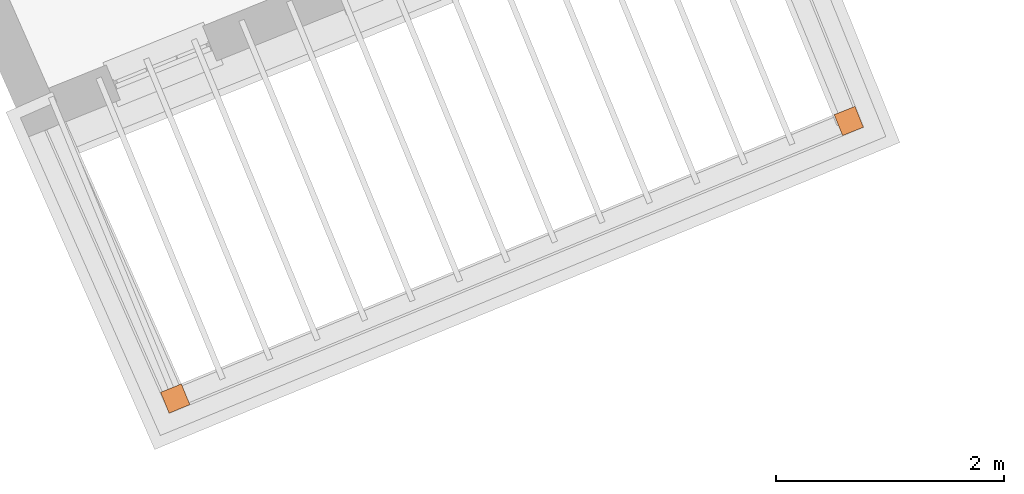
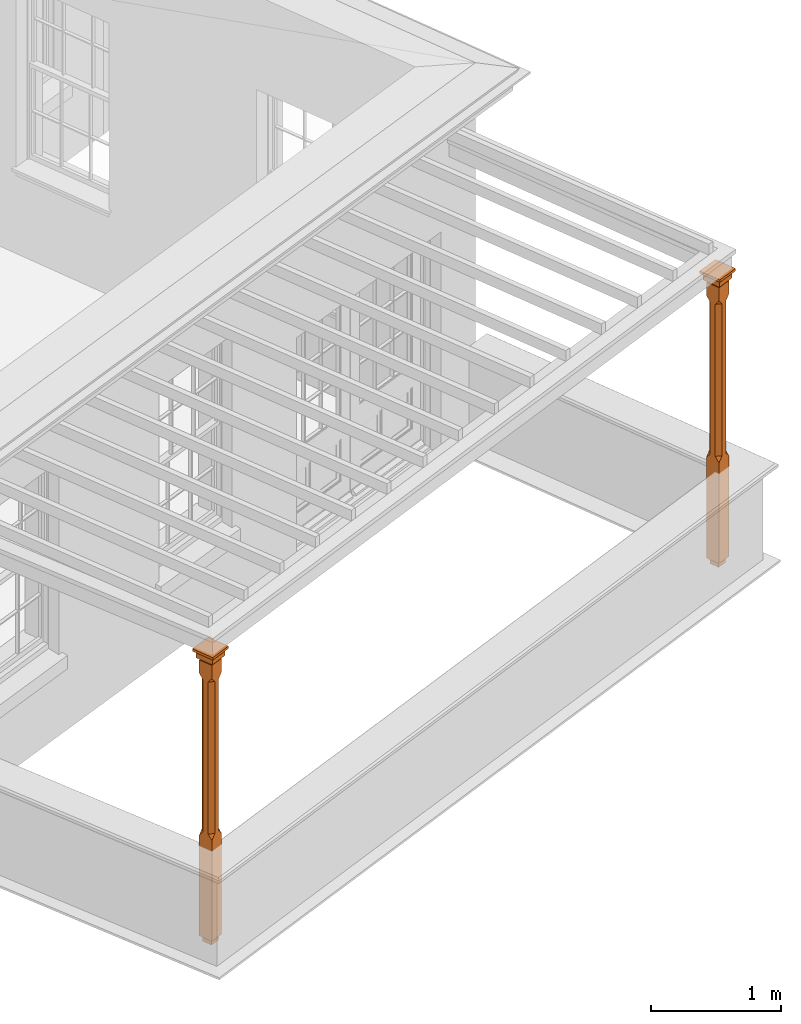
# One storey, part 11 of 11: 2 proxies.
"""IFC2X3 building model written with IfcOpenShell, lengths in metres."""

from ifc_helpers import new_model, si_unit, frame, origin, place, context, subcontext, project, spatial, faceted_brep, element, save


model = new_model("IFC2X3")

# Units and contexts
model_context = context("Model", 3, world=origin())
body_context = subcontext(model_context, "Body", "Model", "MODEL_VIEW")
ifc_project = project(units=[si_unit("PLANEANGLEUNIT", "RADIAN"), si_unit("MASSUNIT", "GRAM", prefix="KILO"), si_unit("FORCEUNIT", "NEWTON", prefix="KILO"), si_unit("LENGTHUNIT", "METRE")], contexts=[model_context])

# Site, building, storey
site_placement = place(None, origin())
site = spatial("IfcSite", under=ifc_project, at=site_placement, CompositionType="ELEMENT")
building_placement = place(None, origin())
building = spatial("IfcBuilding", under=site, at=building_placement, Name="Building plot-6", CompositionType="ELEMENT")
storey_placement = place(None, frame((0.0, 0.0, 7.6)))
storey = spatial("IfcBuildingStorey", under=building, at=storey_placement, Name="Floor 1", CompositionType="ELEMENT", Elevation=7.6)

# Proxies
proxy_1_placement = place(storey_placement, frame((68.3815028895231, 53.2647282573946, 0.0), z_axis=(0.0, 0.0, 1.0), x_axis=(0.9245784791748, 0.380991648001388, 0.0)))
element("IfcBuildingElementProxy", 1, at=proxy_1_placement, inside=storey, Name="pergola post", CompositionType="ELEMENT", context=body_context, shape_type="Brep", held_by="IfcProductRepresentation", body=[
    faceted_brep([(0.0246, -0.0615, 2.47), (0.0615, -0.0246, 2.47), (0.0615, -0.0615, 2.516667), (0.0615, -0.0246, 1.044444), (0.0246, -0.0615, 1.044444), (0.0615, 0.0246, 2.47), (0.0615, 0.0615, 2.516667), (-0.0246, -0.0615, 2.47), (-0.0615, -0.0615, 2.516667), (-0.0246, -0.0615, 1.044444), (0.0615, -0.0615, 0.997778), (0.0615, 0.0246, 1.044444), (0.0246, 0.0615, 2.47), (0.0615, 0.0615, 2.641111), (0.0615, -0.0615, 2.641111), (-0.0615, -0.0615, 2.641111), (-0.0615, -0.0246, 2.47), (-0.0615, -0.0246, 1.044444), (-0.0615, -0.0615, 0.997778), (0.0615, 0.0615, 0.997778), (0.0246, 0.0615, 1.044444), (-0.0246, 0.0615, 2.47), (-0.0615, 0.0615, 2.516667), (0.04305, 0.04305, 2.641111), (0.04305, -0.04305, 2.641111), (-0.0615, 0.0615, 2.641111), (-0.04305, -0.04305, 2.641111), (-0.0615, 0.0246, 2.47), (-0.0615, 0.0246, 1.044444), (0.0615, -0.0615, 0.053333), (-0.0615, -0.0615, 0.053333), (0.0615, 0.0615, 0.053333), (-0.0246, 0.0615, 1.044444), (-0.04305, 0.04305, 2.641111), (0.04305, 0.04305, 2.664444), (0.04305, -0.04305, 2.664444), (-0.04305, -0.04305, 2.664444), (-0.0615, 0.0615, 0.997778), (-0.0615, 0.0615, 0.053333), (-0.04305, -0.04305, 0.053333), (0.04305, -0.04305, 0.053333), (0.04305, 0.04305, 0.053333), (-0.04305, 0.04305, 2.664444), (0.07995, 0.07995, 2.664444), (0.07995, -0.07995, 2.664444), (-0.07995, -0.07995, 2.664444), (-0.04305, 0.04305, 0.053333), (-0.04305, -0.04305, 0.0), (0.04305, -0.04305, 0.0), (0.04305, 0.04305, 0.0), (-0.07995, 0.07995, 2.664444), (0.07995, 0.07995, 2.726667), (0.07995, -0.07995, 2.726667), (-0.07995, -0.07995, 2.726667), (-0.04305, 0.04305, 0.0), (-0.07995, 0.07995, 2.726667), (0.0984, 0.0984, 2.726667), (0.0984, -0.0984, 2.726667), (-0.0984, -0.0984, 2.726667), (-0.0984, 0.0984, 2.726667), (0.0984, 0.0984, 2.75), (0.0984, -0.0984, 2.75), (-0.0984, -0.0984, 2.75), (-0.0984, 0.0984, 2.75)], [[[0, 1, 2]], [[3, 1, 0, 4]], [[1, 5, 6, 2]], [[7, 0, 2, 8]], [[4, 0, 7, 9]], [[3, 4, 10]], [[1, 3, 11, 5]], [[5, 12, 6]], [[13, 14, 2, 6]], [[15, 8, 2, 14]], [[8, 16, 7]], [[9, 7, 16, 17]], [[9, 18, 10, 4]], [[3, 10, 19, 11]], [[20, 12, 5, 11]], [[21, 22, 6, 12]], [[14, 13, 23, 24]], [[13, 6, 22, 25]], [[25, 22, 8, 15]], [[26, 15, 14, 24]], [[16, 8, 22, 27]], [[27, 28, 17, 16]], [[17, 18, 9]], [[29, 10, 18, 30]], [[31, 19, 10, 29]], [[20, 11, 19]], [[12, 20, 32, 21]], [[21, 27, 22]], [[33, 23, 13, 25]], [[23, 34, 35, 24]], [[26, 33, 25, 15]], [[36, 26, 24, 35]], [[28, 27, 21, 32]], [[17, 28, 37, 18]], [[38, 30, 18, 37]], [[29, 30, 39, 40]], [[31, 38, 37, 19]], [[40, 41, 31, 29]], [[32, 20, 19, 37]], [[33, 42, 34, 23]], [[43, 44, 35, 34]], [[42, 33, 26, 36]], [[36, 35, 44, 45]], [[28, 32, 37]], [[46, 39, 30, 38]], [[39, 47, 48, 40]], [[46, 38, 31, 41]], [[49, 41, 40, 48]], [[43, 34, 42, 50]], [[43, 51, 52, 44]], [[45, 50, 42, 36]], [[53, 45, 44, 52]], [[46, 54, 47, 39]], [[54, 46, 41, 49]], [[50, 55, 51, 43]], [[56, 57, 52, 51]], [[55, 50, 45, 53]], [[53, 52, 57, 58]], [[56, 51, 55, 59]], [[56, 60, 61, 57]], [[58, 59, 55, 53]], [[62, 58, 57, 61]], [[59, 63, 60, 56]], [[63, 62, 61, 60]], [[58, 62, 63, 59]], [[47, 54, 49, 48]]]),
])
proxy_2_placement = place(storey_placement, frame((74.2860954362417, 55.6978375021164, 0.0), z_axis=(0.0, 0.0, 1.0), x_axis=(-0.373808818396178, 0.927505777496428, 0.0)))
element("IfcBuildingElementProxy", 2, at=proxy_2_placement, inside=storey, Name="pergola post", CompositionType="ELEMENT", context=body_context, shape_type="Brep", held_by="IfcProductRepresentation", body=[
    faceted_brep([(0.0246, -0.0615, 2.47), (0.0615, -0.0246, 2.47), (0.0615, -0.0615, 2.516667), (0.0615, -0.0246, 1.044444), (0.0246, -0.0615, 1.044444), (0.0615, 0.0246, 2.47), (0.0615, 0.0615, 2.516667), (-0.0246, -0.0615, 2.47), (-0.0615, -0.0615, 2.516667), (-0.0246, -0.0615, 1.044444), (0.0615, -0.0615, 0.997778), (0.0615, 0.0246, 1.044444), (0.0246, 0.0615, 2.47), (0.0615, 0.0615, 2.641111), (0.0615, -0.0615, 2.641111), (-0.0615, -0.0615, 2.641111), (-0.0615, -0.0246, 2.47), (-0.0615, -0.0246, 1.044444), (-0.0615, -0.0615, 0.997778), (0.0615, 0.0615, 0.997778), (0.0246, 0.0615, 1.044444), (-0.0246, 0.0615, 2.47), (-0.0615, 0.0615, 2.516667), (0.04305, 0.04305, 2.641111), (0.04305, -0.04305, 2.641111), (-0.0615, 0.0615, 2.641111), (-0.04305, -0.04305, 2.641111), (-0.0615, 0.0246, 2.47), (-0.0615, 0.0246, 1.044444), (0.0615, -0.0615, 0.053333), (-0.0615, -0.0615, 0.053333), (0.0615, 0.0615, 0.053333), (-0.0246, 0.0615, 1.044444), (-0.04305, 0.04305, 2.641111), (0.04305, 0.04305, 2.664444), (0.04305, -0.04305, 2.664444), (-0.04305, -0.04305, 2.664444), (-0.0615, 0.0615, 0.997778), (-0.0615, 0.0615, 0.053333), (-0.04305, -0.04305, 0.053333), (0.04305, -0.04305, 0.053333), (0.04305, 0.04305, 0.053333), (-0.04305, 0.04305, 2.664444), (0.07995, 0.07995, 2.664444), (0.07995, -0.07995, 2.664444), (-0.07995, -0.07995, 2.664444), (-0.04305, 0.04305, 0.053333), (-0.04305, -0.04305, 0.0), (0.04305, -0.04305, 0.0), (0.04305, 0.04305, 0.0), (-0.07995, 0.07995, 2.664444), (0.07995, 0.07995, 2.726667), (0.07995, -0.07995, 2.726667), (-0.07995, -0.07995, 2.726667), (-0.04305, 0.04305, 0.0), (-0.07995, 0.07995, 2.726667), (0.0984, 0.0984, 2.726667), (0.0984, -0.0984, 2.726667), (-0.0984, -0.0984, 2.726667), (-0.0984, 0.0984, 2.726667), (0.0984, 0.0984, 2.75), (0.0984, -0.0984, 2.75), (-0.0984, -0.0984, 2.75), (-0.0984, 0.0984, 2.75)], [[[0, 1, 2]], [[3, 1, 0, 4]], [[1, 5, 6, 2]], [[7, 0, 2, 8]], [[4, 0, 7, 9]], [[3, 4, 10]], [[1, 3, 11, 5]], [[5, 12, 6]], [[13, 14, 2, 6]], [[15, 8, 2, 14]], [[8, 16, 7]], [[9, 7, 16, 17]], [[9, 18, 10, 4]], [[3, 10, 19, 11]], [[20, 12, 5, 11]], [[21, 22, 6, 12]], [[14, 13, 23, 24]], [[13, 6, 22, 25]], [[25, 22, 8, 15]], [[26, 15, 14, 24]], [[16, 8, 22, 27]], [[27, 28, 17, 16]], [[17, 18, 9]], [[29, 10, 18, 30]], [[31, 19, 10, 29]], [[20, 11, 19]], [[12, 20, 32, 21]], [[21, 27, 22]], [[33, 23, 13, 25]], [[23, 34, 35, 24]], [[26, 33, 25, 15]], [[36, 26, 24, 35]], [[28, 27, 21, 32]], [[17, 28, 37, 18]], [[38, 30, 18, 37]], [[29, 30, 39, 40]], [[31, 38, 37, 19]], [[40, 41, 31, 29]], [[32, 20, 19, 37]], [[33, 42, 34, 23]], [[43, 44, 35, 34]], [[42, 33, 26, 36]], [[36, 35, 44, 45]], [[28, 32, 37]], [[46, 39, 30, 38]], [[39, 47, 48, 40]], [[46, 38, 31, 41]], [[49, 41, 40, 48]], [[43, 34, 42, 50]], [[43, 51, 52, 44]], [[45, 50, 42, 36]], [[53, 45, 44, 52]], [[46, 54, 47, 39]], [[54, 46, 41, 49]], [[50, 55, 51, 43]], [[56, 57, 52, 51]], [[55, 50, 45, 53]], [[53, 52, 57, 58]], [[56, 51, 55, 59]], [[56, 60, 61, 57]], [[58, 59, 55, 53]], [[62, 58, 57, 61]], [[59, 63, 60, 56]], [[63, 62, 61, 60]], [[58, 62, 63, 59]], [[47, 54, 49, 48]]]),
])

save(model, "model.ifc")
